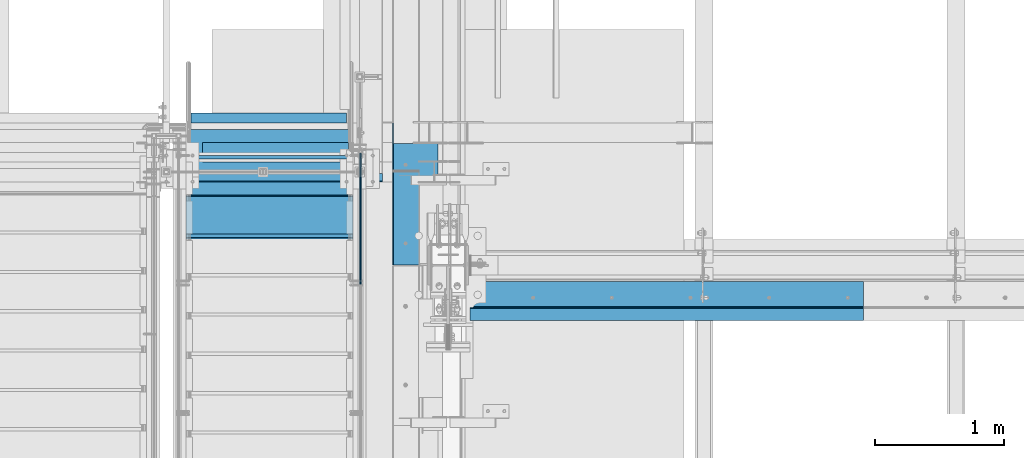
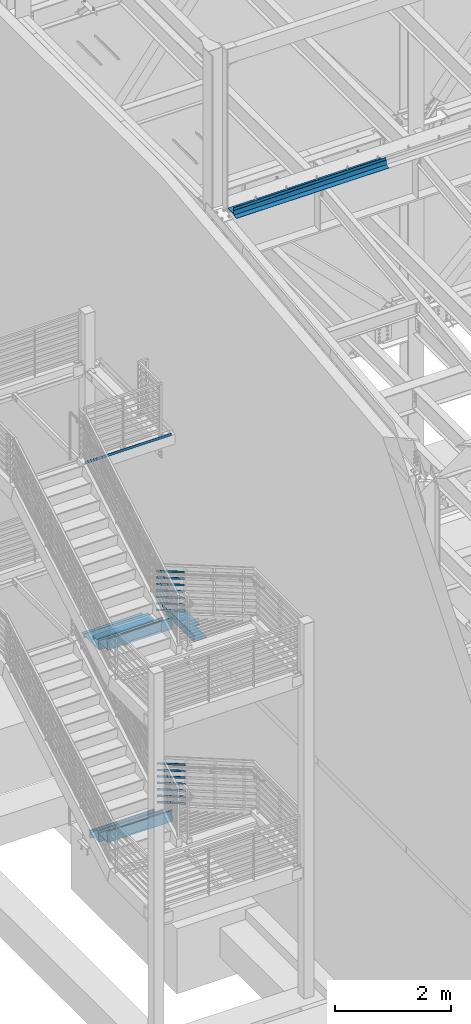
# One storey, part 763 of 1179: 14 members, 11 beams, 9 elements without a shape of their own.
"""IFC2X3 building model written with IfcOpenShell, lengths in millimetres."""

import ifcopenshell
import ifcopenshell.guid

model = None  # the IFC model being written
_history = None  # IfcOwnerHistory: only IFC2X3 demands one
_inside = {}  # id of a spatial element -> (the spatial element, [elements in it])
_under = {}  # id of a project, library or spatial element -> (it, [spatial elements below it])
_declared = {}  # id of a project -> (the project, [libraries it declares])
_typed = {}  # id of a type object -> (the type object, [elements of that type])
_made_of = {}  # id of a material, layer set ... -> (it, [elements and type objects made of it])


def new_model(schema):
    """Start an empty IFC model of exactly this schema.

    Asked for "IFC4X3", IfcOpenShell would pick the latest addendum, in which some entities
    have other attributes; the version numbers below select the first issue.
    IFC2X3 requires an IfcOwnerHistory on every rooted entity: one is made here for all.
    """
    global model, _history
    if schema == "IFC4X3":
        model = ifcopenshell.file(schema_version=(4, 3, 0, 0))
    else:
        model = ifcopenshell.file(schema=schema)
    _inside.clear()
    _under.clear()
    _declared.clear()
    _typed.clear()
    _made_of.clear()
    _history = None
    if model.schema == "IFC2X3":
        org = make("IfcOrganization", Name="unknown")
        user = make(
            "IfcPersonAndOrganization",
            ThePerson=make("IfcPerson", FamilyName="unknown"),
            TheOrganization=org,
        )
        app = make(
            "IfcApplication",
            ApplicationDeveloper=org,
            Version="unknown",
            ApplicationFullName="unknown",
            ApplicationIdentifier="unknown",
        )
        _history = make(
            "IfcOwnerHistory",
            OwningUser=user,
            OwningApplication=app,
            ChangeAction="ADDED",
            CreationDate=0,
        )
    return model


def make(cls, **values):
    """One entity of the class cls with the attributes given. An attribute that is None is left unset."""
    return model.create_entity(
        cls, **{name: value for name, value in values.items() if value is not None}
    )


def rooted(cls, **values):
    """An entity with a GlobalId (a new one), such as an element, a storey or a relation."""
    return make(cls, GlobalId=ifcopenshell.guid.new(), OwnerHistory=_history, **values)


def si_unit(unit_type, name, prefix=None):
    """IfcSIUnit, for example si_unit("LENGTHUNIT", "METRE", prefix="MILLI")."""
    return make("IfcSIUnit", UnitType=unit_type, Prefix=prefix, Name=name)


def assignment(units):
    """IfcUnitAssignment: the units of a project."""
    return None if units is None else make("IfcUnitAssignment", Units=units)


def point(xyz):
    """IfcCartesianPoint."""
    return None if xyz is None else make("IfcCartesianPoint", Coordinates=xyz)


def direction(xyz):
    """IfcDirection."""
    return None if xyz is None else make("IfcDirection", DirectionRatios=xyz)


def frame(location, z_axis=None, x_axis=None):
    """IfcAxis2Placement3D, a coordinate frame: its origin and axes. An axis left out is left unset."""
    return make(
        "IfcAxis2Placement3D",
        Location=point(location),
        Axis=direction(z_axis),
        RefDirection=direction(x_axis),
    )


def origin_with_axes():
    """The frame at (0, 0, 0) with the z axis (0, 0, 1) and the x axis (1, 0, 0) written out."""
    return frame((0.0, 0.0, 0.0), z_axis=(0.0, 0.0, 1.0), x_axis=(1.0, 0.0, 0.0))


def place(relative_to, where):
    """IfcLocalPlacement: puts the frame where relative to a parent placement (None: the world)."""
    return make(
        "IfcLocalPlacement", PlacementRelTo=relative_to, RelativePlacement=where
    )


def context(
    kind, dimensions, precision=None, world=None, true_north=None, identifier=None
):
    """IfcGeometricRepresentationContext, for example the 3D "Model" context."""
    return make(
        "IfcGeometricRepresentationContext",
        ContextIdentifier=identifier,
        ContextType=kind,
        CoordinateSpaceDimension=dimensions,
        Precision=precision,
        WorldCoordinateSystem=world,
        TrueNorth=true_north,
    )


def subcontext(parent, identifier, kind, view, scale=None):
    """IfcGeometricRepresentationSubContext, for example "Body" below "Model"."""
    return make(
        "IfcGeometricRepresentationSubContext",
        ContextIdentifier=identifier,
        ContextType=kind,
        ParentContext=parent,
        TargetScale=scale,
        TargetView=view,
    )


def project(units=None, contexts=None):
    """IfcProject with its units and contexts."""
    return rooted(
        "IfcProject",
        Name="project",
        RepresentationContexts=contexts,
        UnitsInContext=assignment(units),
    )


def spatial(cls, under=None, at=None, **own):
    """A site, building, storey or space (cls), placed at a placement, below another one or the project."""
    s = rooted(cls, ObjectPlacement=at, **own)
    if under is not None:
        _under.setdefault(under.id(), (under, []))[1].append(s)
    return s


def faces_of(points, faces, orient=None, outer=None):
    """IfcFace entities. A face is a list of loops; a loop is a list of indices into points, from 0.

    orient and outer hold one flag for each loop. By default every Orientation is true, the
    first loop of a face is its IfcFaceOuterBound and the others are IfcFaceBound.
    """
    made = []
    for i, loops in enumerate(faces):
        bounds = []
        for j, loop in enumerate(loops):
            is_outer = j == 0 if outer is None else outer[i][j]
            bounds.append(
                make(
                    "IfcFaceOuterBound" if is_outer else "IfcFaceBound",
                    Bound=make("IfcPolyLoop", Polygon=[points[k] for k in loop]),
                    Orientation=True if orient is None else orient[i][j],
                )
            )
        made.append(make("IfcFace", Bounds=bounds))
    return made


def faceted_brep(points, faces, orient=None, outer=None, voids=None):
    """IfcFacetedBrep: a solid bounded by flat faces; with voids (closed shells), ...WithVoids."""
    shared = [point(p) for p in points]
    hull = make("IfcClosedShell", CfsFaces=faces_of(shared, faces, orient, outer))
    if voids is None:
        return make("IfcFacetedBrep", Outer=hull)
    return make(
        "IfcFacetedBrepWithVoids",
        Outer=hull,
        Voids=[
            make(cls, CfsFaces=faces_of(shared, fs, o, b)) for cls, fs, o, b in voids
        ],
    )


def shape(context_of_items, identifier, shape_type, items):
    """IfcShapeRepresentation: the items that make up one representation, for example the "Body"."""
    return make(
        "IfcShapeRepresentation",
        ContextOfItems=context_of_items,
        RepresentationIdentifier=identifier,
        RepresentationType=shape_type,
        Items=items,
    )


def material(Name=None, Category=None):
    """IfcMaterial."""
    return make("IfcMaterial", Name=Name, Category=Category)


def made_of(thing, what):
    """Note that an element or type object is made of a material, layer set ...; save() writes the relation."""
    if what is not None:
        _made_of.setdefault(what.id(), (what, []))[1].append(thing)
    return thing


def type_object(cls, material=None, **own):
    """A type object (cls), such as IfcWallType, which elements share."""
    return made_of(rooted(cls, **own), material)


def element(
    cls,
    number,
    at=None,
    inside=None,
    cuts=None,
    type_object=None,
    material=None,
    context=None,
    identifier="Body",
    shape_type=None,
    held_by="IfcProductDefinitionShape",
    body=None,
    shapes=None,
    **own,
):
    """One element of the class cls, such as IfcWall. Its Tag is "e" and its number.

    at: its placement. inside: the storey or other place that contains it. cuts: it is an
    opening in that element (IfcRelVoidsElement). A single representation is given by context,
    identifier, shape_type and body (its items); several are given by shapes. held_by: the class
    of the entity that holds the representations. save() writes the other relations.
    """
    e = rooted(cls, Tag="e%d" % number, ObjectPlacement=at, **own)
    if body is not None:
        shapes = [shape(context, identifier, shape_type, body)]
    if shapes is not None:
        e.Representation = make(held_by, Representations=shapes)
    if inside is not None:
        _inside.setdefault(inside.id(), (inside, []))[1].append(e)
    if cuts is not None:
        rooted(
            "IfcRelVoidsElement", RelatingBuildingElement=cuts, RelatedOpeningElement=e
        )
    if type_object is not None:
        _typed.setdefault(type_object.id(), (type_object, []))[1].append(e)
    return made_of(e, material)


def aggregate(whole, parts):
    """IfcRelAggregates: a whole, such as a stair, and the parts it consists of."""
    return rooted("IfcRelAggregates", RelatingObject=whole, RelatedObjects=parts)


def save(model, path):
    """Write the relations noted so far, then the file.

    IfcRelAggregates (storeys below a building ...), IfcRelContainedInSpatialStructure (elements
    in a storey), IfcRelDefinesByType, IfcRelAssociatesMaterial and IfcRelDeclares: one each for
    every whole, place, type object, material and project.
    """
    for whole, parts in _under.values():
        aggregate(whole, parts)
    for where, things in _inside.values():
        rooted(
            "IfcRelContainedInSpatialStructure",
            RelatedElements=things,
            RelatingStructure=where,
        )
    for kind, things in _typed.values():
        rooted("IfcRelDefinesByType", RelatedObjects=things, RelatingType=kind)
    for what, things in _made_of.values():
        rooted("IfcRelAssociatesMaterial", RelatedObjects=things, RelatingMaterial=what)
    for by, libraries in _declared.values():
        rooted("IfcRelDeclares", RelatingContext=by, RelatedDefinitions=libraries)
    model.write(path)


model = new_model("IFC2X3")

# Units and contexts
model_context = context("Model", 3, precision=1e-05, world=origin_with_axes())
body_context = subcontext(model_context, "Body", "Model", "MODEL_VIEW")
ifc_project = project(units=[si_unit("LENGTHUNIT", "METRE", prefix="MILLI"), si_unit("AREAUNIT", "SQUARE_METRE"), si_unit("VOLUMEUNIT", "CUBIC_METRE"), si_unit("MASSUNIT", "GRAM", prefix="KILO"), si_unit("TIMEUNIT", "SECOND"), si_unit("PLANEANGLEUNIT", "RADIAN"), si_unit("SOLIDANGLEUNIT", "STERADIAN"), si_unit("THERMODYNAMICTEMPERATUREUNIT", "DEGREE_CELSIUS"), si_unit("LUMINOUSINTENSITYUNIT", "LUMEN")], contexts=[model_context])

# Site, building, storey
site_placement = place(None, origin_with_axes())
site = spatial("IfcSite", under=ifc_project, at=site_placement, CompositionType="ELEMENT")
building_placement = place(site_placement, origin_with_axes())
building = spatial("IfcBuilding", under=site, at=building_placement, Name="Undefined", CompositionType="ELEMENT")
storey_placement = place(building_placement, origin_with_axes())
storey = spatial("IfcBuildingStorey", under=building, at=storey_placement, Name="Undefined", CompositionType="ELEMENT", Elevation=0.0)

# Assembly, beam
assembly_1_placement = place(storey_placement, origin_with_axes())
assembly_1 = element("IfcElementAssembly", 1, at=assembly_1_placement, inside=storey, Name="BEAM", AssemblyPlace="NOTDEFINED", PredefinedType="RIGID_FRAME")
ifc_material = material(Name="STEEL/A36")
beam_type_1 = type_object("IfcBeamType", Name="L3X3X1/4", PredefinedType="NOTDEFINED")
beam_1_placement = place(assembly_1_placement, frame((-1562.09999973749, 35534.6000000027, 4095.75), z_axis=(0.0, 0.0, -1.0), x_axis=(1.0, 0.0, 0.0)))
beam_1 = element("IfcBeam", 2, at=beam_1_placement, type_object=beam_type_1, material=ifc_material, Name="ANGLE", ObjectType="L3X3X1/4", context=body_context, shape_type="Brep", body=[
    faceted_brep([(0.0, 38.0999999999985, -38.0999999999999), (0.0, 38.0999999999985, 38.0999999999999), (1206.49999973749, 38.0999999999985, 38.0999999999999), (1206.49999973749, 38.0999999999985, -38.1000000000004), (0.0, 31.75, 38.1000000000004), (1206.49999973749, 31.75, 38.0999999999999), (0.0, 31.75, -31.75), (1206.49999973749, 31.75, -31.75), (0.0, -38.0999999999985, -31.75), (1206.49999973749, -38.0999999999985, -31.75), (0.0, -38.0999999999985, -38.0999999999999), (1206.49999973749, -38.0999999999985, -38.1000000000004)], [[[0, 1, 2, 3]], [[1, 4, 5, 2]], [[4, 6, 7, 5]], [[6, 8, 9, 7]], [[8, 10, 11, 9]], [[10, 0, 3, 11]], [[5, 7, 9, 11, 3, 2]], [[10, 8, 6, 4, 1, 0]]]),
])

# Assembly, members
assembly_2_placement = place(storey_placement, origin_with_axes())
assembly_2 = element("IfcElementAssembly", 3, at=assembly_2_placement, inside=storey, Name="GUARDRAIL", AssemblyPlace="NOTDEFINED", PredefinedType="RIGID_FRAME")
member_type = type_object("IfcMemberType", PredefinedType="NOTDEFINED")
member_1_placement = place(assembly_2_placement, frame((-247.650000724804, 35271.0012572226, 4335.52619387723), z_axis=(0.0, 0.503871025834968, 0.863778900717086), x_axis=(0.0, -0.863778900717086, 0.503871025834967)))
member_1 = element("IfcMember", 4, at=member_1_placement, type_object=member_type, material=ifc_material, Name="PLATE", context=body_context, shape_type="Brep", body=[
    faceted_brep([(-0.170746091993351, 4.76249999999999, -19.0500000000247), (22.0542539263261, 4.76249999999999, 19.0500000000065), (1164.83261782332, 4.76250000000005, 19.0499999989988), (1142.607617805, 4.76250000000005, -19.0500000010361), (22.0542539263261, -4.76249999999999, 19.0500000000065), (1164.83261782332, -4.76250000000005, 19.0499999989988), (-0.170746091993351, -4.76249999999999, -19.0500000000247), (1142.607617805, -4.76250000000005, -19.0500000010361)], [[[0, 1, 2, 3]], [[1, 4, 5, 2]], [[4, 6, 7, 5]], [[6, 0, 3, 7]], [[5, 7, 3, 2]], [[6, 4, 1, 0]]]),
])
member_2_placement = place(assembly_2_placement, frame((-247.650000724804, 35271.0012572185, 4471.70970347572), z_axis=(0.0, 0.503871025834968, 0.863778900717086), x_axis=(0.0, -0.863778900717086, 0.503871025834967)))
member_2 = element("IfcMember", 5, at=member_2_placement, type_object=member_type, material=ifc_material, Name="PLATE", context=body_context, shape_type="Brep", body=[
    faceted_brep([(-0.170746091993351, 4.76249999999999, -19.0500000000247), (22.0542539263261, 4.76249999999999, 19.0500000000065), (1164.83261782332, 4.76250000000005, 19.0499999989988), (1142.607617805, 4.76250000000005, -19.0500000010361), (22.0542539263261, -4.76249999999999, 19.0500000000065), (1164.83261782332, -4.76250000000005, 19.0499999989988), (-0.170746091993351, -4.76249999999999, -19.0500000000247), (1142.607617805, -4.76250000000005, -19.0500000010361)], [[[0, 1, 2, 3]], [[1, 4, 5, 2]], [[4, 6, 7, 5]], [[6, 0, 3, 7]], [[5, 7, 3, 2]], [[6, 4, 1, 0]]]),
])
member_3_placement = place(assembly_2_placement, frame((-247.650000724804, 35271.0012572142, 4607.89321307448), z_axis=(0.0, 0.503871025834968, 0.863778900717086), x_axis=(0.0, -0.863778900717086, 0.503871025834967)))
member_3 = element("IfcMember", 6, at=member_3_placement, type_object=member_type, material=ifc_material, Name="PLATE", context=body_context, shape_type="Brep", body=[
    faceted_brep([(-0.170746091993351, 4.76249999999999, -19.0500000000247), (22.0542539263261, 4.76249999999999, 19.0500000000065), (1164.83261782332, 4.76250000000005, 19.0499999989988), (1142.607617805, 4.76250000000005, -19.0500000010361), (22.0542539263261, -4.76249999999999, 19.0500000000065), (1164.83261782332, -4.76250000000005, 19.0499999989988), (-0.170746091993351, -4.76249999999999, -19.0500000000247), (1142.607617805, -4.76250000000005, -19.0500000010361)], [[[0, 1, 2, 3]], [[1, 4, 5, 2]], [[4, 6, 7, 5]], [[6, 0, 3, 7]], [[5, 7, 3, 2]], [[6, 4, 1, 0]]]),
])
member_4_placement = place(assembly_2_placement, frame((-247.650000724804, 35271.00125721, 4744.07672267268), z_axis=(0.0, 0.503871025834968, 0.863778900717086), x_axis=(0.0, -0.863778900717086, 0.503871025834967)))
member_4 = element("IfcMember", 7, at=member_4_placement, type_object=member_type, material=ifc_material, Name="PLATE", context=body_context, shape_type="Brep", body=[
    faceted_brep([(-0.170746091993351, 4.76249999999999, -19.0500000000247), (22.0542539263261, 4.76249999999999, 19.0500000000065), (1164.83261782332, 4.76250000000005, 19.0499999989988), (1142.607617805, 4.76250000000005, -19.0500000010361), (22.0542539263261, -4.76249999999999, 19.0500000000065), (1164.83261782332, -4.76250000000005, 19.0499999989988), (-0.170746091993351, -4.76249999999999, -19.0500000000247), (1142.607617805, -4.76250000000005, -19.0500000010361)], [[[0, 1, 2, 3]], [[1, 4, 5, 2]], [[4, 6, 7, 5]], [[6, 0, 3, 7]], [[5, 7, 3, 2]], [[6, 4, 1, 0]]]),
])
member_5_placement = place(assembly_2_placement, frame((-247.650000724804, 35271.0012572057, 4880.26023227058), z_axis=(0.0, 0.503871025834968, 0.863778900717086), x_axis=(0.0, -0.863778900717086, 0.503871025834967)))
member_5 = element("IfcMember", 8, at=member_5_placement, type_object=member_type, material=ifc_material, Name="PLATE", context=body_context, shape_type="Brep", body=[
    faceted_brep([(-0.170746091993351, 4.76249999999999, -19.0500000000247), (22.0542539263261, 4.76249999999999, 19.0500000000065), (1164.83261782332, 4.76250000000005, 19.0499999989988), (1142.607617805, 4.76250000000005, -19.0500000010361), (22.0542539263261, -4.76249999999999, 19.0500000000065), (1164.83261782332, -4.76250000000005, 19.0499999989988), (-0.170746091993351, -4.76249999999999, -19.0500000000247), (1142.607617805, -4.76250000000005, -19.0500000010361)], [[[0, 1, 2, 3]], [[1, 4, 5, 2]], [[4, 6, 7, 5]], [[6, 0, 3, 7]], [[5, 7, 3, 2]], [[6, 4, 1, 0]]]),
])
member_6_placement = place(assembly_2_placement, frame((-247.650000724804, 35271.0012572249, 5152.62725197387), z_axis=(0.0, 0.503871025834968, 0.863778900717086), x_axis=(0.0, -0.863778900717086, 0.503871025834967)))
member_6 = element("IfcMember", 9, at=member_6_placement, type_object=member_type, material=ifc_material, Name="PLATE", context=body_context, shape_type="Brep", body=[
    faceted_brep([(-0.170746091993351, 4.76249999999999, -19.0500000000247), (22.0542539263261, 4.76249999999999, 19.0500000000065), (1164.83261782332, 4.76250000000005, 19.0499999989988), (1142.607617805, 4.76250000000005, -19.0500000010361), (22.0542539263261, -4.76249999999999, 19.0500000000065), (1164.83261782332, -4.76250000000005, 19.0499999989988), (-0.170746091993351, -4.76249999999999, -19.0500000000247), (1142.607617805, -4.76250000000005, -19.0500000010361)], [[[0, 1, 2, 3]], [[1, 4, 5, 2]], [[4, 6, 7, 5]], [[6, 0, 3, 7]], [[5, 7, 3, 2]], [[6, 4, 1, 0]]]),
])
member_7_placement = place(assembly_2_placement, frame((-247.650000724804, 35271.0012572016, 5016.44374186906), z_axis=(0.0, 0.503871025834968, 0.863778900717086), x_axis=(0.0, -0.863778900717086, 0.503871025834967)))
member_7 = element("IfcMember", 10, at=member_7_placement, type_object=member_type, material=ifc_material, Name="PLATE", context=body_context, shape_type="Brep", body=[
    faceted_brep([(-0.170746091993351, 4.76249999999999, -19.0500000000247), (22.0542539263261, 4.76249999999999, 19.0500000000065), (1164.83261782332, 4.76250000000005, 19.0499999989988), (1142.607617805, 4.76250000000005, -19.0500000010361), (22.0542539263261, -4.76249999999999, 19.0500000000065), (1164.83261782332, -4.76250000000005, 19.0499999989988), (-0.170746091993351, -4.76249999999999, -19.0500000000247), (1142.607617805, -4.76250000000005, -19.0500000010361)], [[[0, 1, 2, 3]], [[1, 4, 5, 2]], [[4, 6, 7, 5]], [[6, 0, 3, 7]], [[5, 7, 3, 2]], [[6, 4, 1, 0]]]),
])
aggregate(assembly_2, [member_1, member_2, member_3, member_4, member_5, member_6, member_7])

assembly_3_placement = place(storey_placement, origin_with_axes())
assembly_3 = element("IfcElementAssembly", 11, at=assembly_3_placement, inside=storey, Name="GUARDRAIL", AssemblyPlace="NOTDEFINED", PredefinedType="RIGID_FRAME")
member_8_placement = place(assembly_3_placement, frame((-247.650000724804, 35232.9545867769, 299.274981469476), z_axis=(0.0, 0.501075923252298, 0.865403327435744), x_axis=(0.0, -0.865403327435743, 0.501075923252299)))
member_8 = element("IfcMember", 12, at=member_8_placement, type_object=member_type, material=ifc_material, Name="PLATE", context=body_context, shape_type="Brep", body=[
    faceted_brep([(-0.0473691999795847, 4.76250000000005, -19.0500000000138), (22.0128564435363, 4.76250000000005, 19.0500000000102), (1153.84060725657, 4.76250000000005, 19.0499999998246), (1131.78038161306, 4.76250000000005, -19.0500000001994), (22.0128564435363, -4.76250000000005, 19.0500000000102), (1153.84060725657, -4.76250000000005, 19.0499999998246), (-0.0473691999795847, -4.76250000000005, -19.0500000000138), (1131.78038161306, -4.76250000000005, -19.0500000001994)], [[[0, 1, 2, 3]], [[1, 4, 5, 2]], [[4, 6, 7, 5]], [[6, 0, 3, 7]], [[5, 7, 3, 2]], [[6, 4, 1, 0]]]),
])
member_9_placement = place(assembly_3_placement, frame((-247.650000724804, 35232.9545713406, 435.375696171575), z_axis=(0.0, 0.501075923252298, 0.865403327435744), x_axis=(0.0, -0.865403327435743, 0.501075923252299)))
member_9 = element("IfcMember", 13, at=member_9_placement, type_object=member_type, material=ifc_material, Name="PLATE", context=body_context, shape_type="Brep", body=[
    faceted_brep([(-0.0473691999795847, 4.76250000000005, -19.0500000000138), (22.0128564435363, 4.76250000000005, 19.0500000000102), (1153.84060725657, 4.76250000000005, 19.0499999998246), (1131.78038161306, 4.76250000000005, -19.0500000001994), (22.0128564435363, -4.76250000000005, 19.0500000000102), (1153.84060725657, -4.76250000000005, 19.0499999998246), (-0.0473691999795847, -4.76250000000005, -19.0500000000138), (1131.78038161306, -4.76250000000005, -19.0500000001994)], [[[0, 1, 2, 3]], [[1, 4, 5, 2]], [[4, 6, 7, 5]], [[6, 0, 3, 7]], [[5, 7, 3, 2]], [[6, 4, 1, 0]]]),
])
member_10_placement = place(assembly_3_placement, frame((-247.650000724804, 35232.9545553325, 571.476410876199), z_axis=(0.0, 0.501075923252298, 0.865403327435744), x_axis=(0.0, -0.865403327435743, 0.501075923252299)))
member_10 = element("IfcMember", 14, at=member_10_placement, type_object=member_type, material=ifc_material, Name="PLATE", context=body_context, shape_type="Brep", body=[
    faceted_brep([(-0.0473691999795847, 4.76250000000005, -19.0500000000138), (22.0128564435363, 4.76250000000005, 19.0500000000102), (1153.84060725657, 4.76250000000005, 19.0499999998246), (1131.78038161306, 4.76250000000005, -19.0500000001994), (22.0128564435363, -4.76250000000005, 19.0500000000102), (1153.84060725657, -4.76250000000005, 19.0499999998246), (-0.0473691999795847, -4.76250000000005, -19.0500000000138), (1131.78038161306, -4.76250000000005, -19.0500000001994)], [[[0, 1, 2, 3]], [[1, 4, 5, 2]], [[4, 6, 7, 5]], [[6, 0, 3, 7]], [[5, 7, 3, 2]], [[6, 4, 1, 0]]]),
])
member_11_placement = place(assembly_3_placement, frame((-247.650000724804, 35232.9545387317, 707.577125627306), z_axis=(0.0, 0.501075923252298, 0.865403327435744), x_axis=(0.0, -0.865403327435743, 0.501075923252299)))
member_11 = element("IfcMember", 15, at=member_11_placement, type_object=member_type, material=ifc_material, Name="PLATE", context=body_context, shape_type="Brep", body=[
    faceted_brep([(-0.0473691999795847, 4.76250000000005, -19.0500000000138), (22.0128564435363, 4.76250000000005, 19.0500000000102), (1153.84060725657, 4.76250000000005, 19.0499999998246), (1131.78038161306, 4.76250000000005, -19.0500000001994), (22.0128564435363, -4.76250000000005, 19.0500000000102), (1153.84060725657, -4.76250000000005, 19.0499999998246), (-0.0473691999795847, -4.76250000000005, -19.0500000000138), (1131.78038161306, -4.76250000000005, -19.0500000001994)], [[[0, 1, 2, 3]], [[1, 4, 5, 2]], [[4, 6, 7, 5]], [[6, 0, 3, 7]], [[5, 7, 3, 2]], [[6, 4, 1, 0]]]),
])
member_12_placement = place(assembly_3_placement, frame((-247.650000724804, 35232.9545215159, 843.677840380916), z_axis=(0.0, 0.501075923252298, 0.865403327435744), x_axis=(0.0, -0.865403327435743, 0.501075923252299)))
member_12 = element("IfcMember", 16, at=member_12_placement, type_object=member_type, material=ifc_material, Name="PLATE", context=body_context, shape_type="Brep", body=[
    faceted_brep([(-0.0473691999795847, 4.76250000000005, -19.0500000000138), (22.0128564435363, 4.76250000000005, 19.0500000000102), (1153.84060725657, 4.76250000000005, 19.0499999998246), (1131.78038161306, 4.76250000000005, -19.0500000001994), (22.0128564435363, -4.76250000000005, 19.0500000000102), (1153.84060725657, -4.76250000000005, 19.0499999998246), (-0.0473691999795847, -4.76250000000005, -19.0500000000138), (1131.78038161306, -4.76250000000005, -19.0500000001994)], [[[0, 1, 2, 3]], [[1, 4, 5, 2]], [[4, 6, 7, 5]], [[6, 0, 3, 7]], [[5, 7, 3, 2]], [[6, 4, 1, 0]]]),
])
member_13_placement = place(assembly_3_placement, frame((-247.650000724804, 35232.9545036904, 1115.87926984463), z_axis=(0.0, 0.501075923252298, 0.865403327435744), x_axis=(0.0, -0.865403327435743, 0.501075923252299)))
member_13 = element("IfcMember", 17, at=member_13_placement, type_object=member_type, material=ifc_material, Name="PLATE", context=body_context, shape_type="Brep", body=[
    faceted_brep([(-0.0473691999795847, 4.76250000000005, -19.0500000000138), (22.0128564435363, 4.76250000000005, 19.0500000000102), (1153.84060725657, 4.76250000000005, 19.0499999998246), (1131.78038161306, 4.76250000000005, -19.0500000001994), (22.0128564435363, -4.76250000000005, 19.0500000000102), (1153.84060725657, -4.76250000000005, 19.0499999998246), (-0.0473691999795847, -4.76250000000005, -19.0500000000138), (1131.78038161306, -4.76250000000005, -19.0500000001994)], [[[0, 1, 2, 3]], [[1, 4, 5, 2]], [[4, 6, 7, 5]], [[6, 0, 3, 7]], [[5, 7, 3, 2]], [[6, 4, 1, 0]]]),
])
member_14_placement = place(assembly_3_placement, frame((-247.650000724804, 35232.9545036625, 979.778555134521), z_axis=(0.0, 0.501075923252298, 0.865403327435744), x_axis=(0.0, -0.865403327435743, 0.501075923252299)))
member_14 = element("IfcMember", 18, at=member_14_placement, type_object=member_type, material=ifc_material, Name="PLATE", context=body_context, shape_type="Brep", body=[
    faceted_brep([(-0.0473691999795847, 4.76250000000005, -19.0500000000138), (22.0128564435363, 4.76250000000005, 19.0500000000102), (1153.84060725657, 4.76250000000005, 19.0499999998246), (1131.78038161306, 4.76250000000005, -19.0500000001994), (22.0128564435363, -4.76250000000005, 19.0500000000102), (1153.84060725657, -4.76250000000005, 19.0499999998246), (-0.0473691999795847, -4.76250000000005, -19.0500000000138), (1131.78038161306, -4.76250000000005, -19.0500000001994)], [[[0, 1, 2, 3]], [[1, 4, 5, 2]], [[4, 6, 7, 5]], [[6, 0, 3, 7]], [[5, 7, 3, 2]], [[6, 4, 1, 0]]]),
])
aggregate(assembly_3, [member_8, member_9, member_10, member_11, member_12, member_13, member_14])

# Beam
beam_type_2 = type_object("IfcBeamType", Name="L6X3-1/2X3/8", PredefinedType="NOTDEFINED")
beam_2_placement = place(assembly_1_placement, frame((-1473.19999987718, 35267.9000000027, 4137.02499999882), z_axis=(0.0, -1.0, 0.0), x_axis=(1.0, 0.0, 0.0)))
beam_2 = element("IfcBeam", 19, at=beam_2_placement, type_object=beam_type_2, material=ifc_material, Name="ANGLE", ObjectType="L6X3-1/2X3/8", context=body_context, shape_type="Brep", body=[
    faceted_brep([(0.0, 44.4499999999998, -76.1999999999971), (0.0, 44.4499999999998, 76.1999999999971), (1133.47499978257, 44.4499999999998, 76.1999999999971), (1133.47499978257, 44.4499999999998, -76.1999999999971), (0.0, 34.9250000000002, 76.1999999999971), (1133.47499978257, 34.9250000000002, 76.1999999999971), (0.0, 34.9250000000002, -66.6750000000029), (1133.47499978257, 34.9250000000002, -66.6750000000029), (0.0, -44.4499999999998, -66.6750000000029), (1133.47499978257, -44.4499999999998, -66.6750000000029), (0.0, -44.4499999999998, -76.1999999999971), (1133.47499978257, -44.4499999999998, -76.1999999999971)], [[[0, 1, 2, 3]], [[1, 4, 5, 2]], [[4, 6, 7, 5]], [[6, 8, 9, 7]], [[8, 10, 11, 9]], [[10, 0, 3, 11]], [[5, 7, 9, 11, 3, 2]], [[10, 8, 6, 4, 1, 0]]]),
])

aggregate(assembly_1, [beam_1, beam_2])

# Assembly, beams
assembly_4_placement = place(storey_placement, origin_with_axes())
assembly_4 = element("IfcElementAssembly", 20, at=assembly_4_placement, inside=storey, Name="STRINGER", AssemblyPlace="NOTDEFINED", PredefinedType="RIGID_FRAME")
beam_type_3 = type_object("IfcBeamType", PredefinedType="NOTDEFINED")
beam_3_placement = place(assembly_4_placement, frame((-952.499999979436, 34607.5013836102, 527.853371605209), z_axis=(-1.0, 0.0, 0.0), x_axis=(0.0, 1.0, 0.0)))
beam_3 = element("IfcBeam", 21, at=beam_3_placement, type_object=beam_type_3, material=ifc_material, Name="TREAD", context=body_context, shape_type="Brep", body=[
    faceted_brep([(-5.47515810467303e-10, -1.58750000000146, -647.7), (-5.47515810467303e-10, -1.58750000000146, 647.7), (5.49334799870849e-10, 1.58749999999418, 647.7), (5.49334799870849e-10, 1.58749999999418, -647.7), (21.7353257776667, 1.58750000000009, 647.7), (21.7353257776667, 1.58750000000009, -647.7), (25.4000000001688, -1.58750000000009, -647.7), (25.4000000001688, -1.58750000000009, 647.7), (-10.9760191413625, 228.869394137143, 647.7), (-10.9760191413625, 228.869394137143, -647.7), (-7.31134491886041, 225.694394137142, -647.7), (-7.31134491886041, 225.694394137142, 647.7), (319.224134592409, 228.869394137143, 647.7), (319.224134592409, 228.869394137143, -647.7), (316.473378484785, 225.694394137142, -647.7), (316.473378484785, 225.694394137142, 647.7), (325.043579912828, 188.435270791671, 647.7), (325.043579912828, 188.435270791671, -647.7), (321.900961419207, 187.982972213801, 647.7), (321.900961419207, 187.982972213801, -647.7)], [[[0, 1, 2, 3]], [[3, 2, 4, 5]], [[1, 0, 6, 7]], [[5, 4, 8, 9]], [[7, 6, 10, 11]], [[9, 8, 12, 13]], [[11, 10, 14, 15]], [[13, 12, 16, 17]], [[12, 8, 4, 2, 1, 7, 11, 15, 18, 16]], [[15, 14, 19, 18]], [[14, 10, 6, 0, 3, 5, 9, 13, 17, 19]], [[18, 19, 17, 16]]]),
])
beam_4_placement = place(assembly_4_placement, frame((-952.499999979396, 34912.3015373443, 351.371477468066), z_axis=(-1.0, 0.0, 0.0), x_axis=(0.0, 1.0, 0.0)))
beam_4 = element("IfcBeam", 22, at=beam_4_placement, type_object=beam_type_3, material=ifc_material, Name="TREAD", context=body_context, shape_type="Brep", body=[
    faceted_brep([(-5.47515810467303e-10, -1.58750000000146, -647.7), (-5.47515810467303e-10, -1.58750000000146, 647.7), (5.49334799870849e-10, 1.58749999999418, 647.7), (5.49334799870849e-10, 1.58749999999418, -647.7), (21.7353257776667, 1.58750000000009, 647.7), (21.7353257776667, 1.58750000000009, -647.7), (25.4000000001688, -1.58750000000009, -647.7), (25.4000000001688, -1.58750000000009, 647.7), (-10.9760191413625, 228.869394137143, 647.7), (-10.9760191413625, 228.869394137143, -647.7), (-7.31134491886041, 225.694394137142, -647.7), (-7.31134491886041, 225.694394137142, 647.7), (319.224134592409, 228.869394137143, 647.7), (319.224134592409, 228.869394137143, -647.7), (316.473378484785, 225.694394137142, -647.7), (316.473378484785, 225.694394137142, 647.7), (325.043579912828, 188.435270791671, 647.7), (325.043579912828, 188.435270791671, -647.7), (321.900961419207, 187.982972213801, 647.7), (321.900961419207, 187.982972213801, -647.7)], [[[0, 1, 2, 3]], [[3, 2, 4, 5]], [[1, 0, 6, 7]], [[5, 4, 8, 9]], [[7, 6, 10, 11]], [[9, 8, 12, 13]], [[11, 10, 14, 15]], [[13, 12, 16, 17]], [[12, 8, 4, 2, 1, 7, 11, 15, 18, 16]], [[15, 14, 19, 18]], [[14, 10, 6, 0, 3, 5, 9, 13, 17, 19]], [[18, 19, 17, 16]]]),
])

# Assembly, beam
assembly_5_placement = place(storey_placement, origin_with_axes())
assembly_5 = element("IfcElementAssembly", 23, at=assembly_5_placement, inside=storey, Name="BEAM", AssemblyPlace="NOTDEFINED", PredefinedType="RIGID_FRAME")
beam_type_4 = type_object("IfcBeamType", PredefinedType="NOTDEFINED")
beam_5_placement = place(assembly_5_placement, frame((-936.625002098729, 35102.800036508, 8096.25000344166), z_axis=(-1.0, 0.0, 0.0), x_axis=(0.0, -1.0, 0.0)))
beam_5 = element("IfcBeam", 24, at=beam_5_placement, type_object=beam_type_4, material=ifc_material, Name="BENT_PLATE", context=body_context, shape_type="Brep", body=[
    faceted_brep([(19.0500096681717, -3.17500000216842, -714.374998184761), (19.0500090585629, 3.17499999783104, -714.374998184761), (1.16415321826935e-09, 3.17500000000018, -714.374997460816), (4.43833414465189e-10, -3.17500000000018, -714.374997460816), (19.0500120810248, -3.17500000216933, -650.874998184761), (19.0500114714159, 3.17499999783104, -650.874998184761), (3.71073838323355e-10, -3.17500000000018, -650.874997460816), (1.09139364212751e-09, 3.17500000000018, -650.874997460816), (63.500001910521, -3.17500000722976, 860.424999999928), (63.5000019100116, -3.17500000722976, -860.425000000073), (63.4999967294498, 50.7999987117846, -860.425000000146), (63.4999967275944, 50.7999987142302, 860.424999999855), (19.050038139867, -3.17500000216842, 34.9249994962848), (19.0500375302581, 3.17499999783104, 34.9249994962847), (3.12866177409887e-10, 3.17500000000018, 34.9250002202299), (-4.00177668780088e-10, -3.17500000000018, 34.9250002202298), (19.05004055272, -3.17500000216933, 98.424999496285), (19.0500399431112, 3.17499999783104, 98.424999496285), (-4.72937244921923e-10, -3.17500000000018, 98.42500022023), (2.40106601268053e-10, 3.17500000000018, 98.42500022023), (-1.25146470963955e-09, -3.17500000000018, 784.224997901276), (-5.3114490583539e-10, 3.17500000000018, 784.224997901277), (19.0500666115549, -3.17500000216842, 784.22499717733), (19.0500660019534, 3.17499999783104, 784.22499717733), (19.0500687831081, -3.17500000216933, 860.42499999994), (19.0500681734993, 3.17499999783104, 860.424999999979), (57.1499967275959, 50.7999981046196, 860.424999999863), (57.150001300899, 3.17499999349366, 860.424999999936), (57.150001300397, 3.17499999349366, -860.425000000066), (57.149996729444, 50.799998102174, -860.425000000138), (6.03904481977224e-10, -3.17500000000018, -860.425), (1.32422428578138e-09, 3.17500000000018, -860.425)], [[[0, 1, 2, 3]], [[4, 5, 1, 0]], [[6, 7, 5, 4]], [[8, 9, 10, 11]], [[12, 13, 14, 15]], [[16, 17, 13, 12]], [[18, 19, 17, 16]], [[20, 21, 19, 18]], [[22, 23, 21, 20]], [[24, 25, 23, 22]], [[8, 11, 26, 27, 25, 24]], [[28, 27, 26, 29]], [[11, 10, 29, 26]], [[9, 30, 31, 28, 29, 10]], [[31, 30, 3, 2]], [[14, 13, 17, 19, 21, 23, 25, 27, 28, 31, 2, 1, 5, 7]], [[15, 14, 7, 6]], [[3, 30, 9, 8, 24, 22, 20, 18, 16, 12, 15, 6, 4, 0]]]),
])
aggregate(assembly_5, [beam_5])

assembly_6_placement = place(storey_placement, origin_with_axes())
assembly_6 = element("IfcElementAssembly", 25, at=assembly_6_placement, inside=storey, Name="BENT_PLATE", AssemblyPlace="NOTDEFINED", PredefinedType="RIGID_FRAME")
beam_type_5 = type_object("IfcBeamType", PredefinedType="NOTDEFINED")
beam_6_placement = place(assembly_6_placement, frame((2125.66250079684, 34061.4000000402, 13197.7319337816), z_axis=(1.0, 0.0, 0.0), x_axis=(0.0, 0.0, -1.0)))
beam_6 = element("IfcBeam", 26, at=beam_6_placement, type_object=beam_type_5, material=ifc_material, Name="BENT_PLATE", context=body_context, shape_type="Brep", body=[
    faceted_brep([(0.0, -3.17499999999927, -1524.0), (6.00266503170133e-10, -3.17499999922438, 1524.00000000052), (6.00266503170133e-10, 3.17500000077416, 1524.00000000052), (0.0, 3.17499999999927, -1524.0), (101.599999999993, 3.17500000000291, 1524.0), (101.599999999993, 3.17500000000291, -1524.0), (95.9271295501057, -3.17500000000291, -1524.0), (95.9271295501057, -3.17500000000291, 1524.0), (113.008063243053, -97.7824964679457, 1524.0), (113.008063243053, -97.7824964679457, -1524.0), (106.698219713815, -98.4955004206422, 1524.0), (106.698219713815, -98.4955004206422, -1524.0)], [[[0, 1, 2, 3]], [[3, 2, 4, 5]], [[1, 0, 6, 7]], [[5, 4, 8, 9]], [[4, 2, 1, 7, 10, 8]], [[7, 6, 11, 10]], [[6, 0, 3, 5, 9, 11]], [[10, 11, 9, 8]]]),
])
aggregate(assembly_6, [beam_6])

assembly_7_placement = place(storey_placement, origin_with_axes())
assembly_7 = element("IfcElementAssembly", 27, at=assembly_7_placement, inside=storey, Name="BEAM", AssemblyPlace="NOTDEFINED", PredefinedType="RIGID_FRAME")
beam_type_6 = type_object("IfcBeamType", PredefinedType="NOTDEFINED")
beam_7_placement = place(assembly_7_placement, frame((2125.66250081644, 34267.775, 13122.275), z_axis=(1.0, 0.0, 0.0), x_axis=(0.0, -1.0, 0.0)))
beam_7 = element("IfcBeam", 28, at=beam_7_placement, type_object=beam_type_6, material=ifc_material, Name="BENT_PLATE", context=body_context, shape_type="Brep", body=[
    faceted_brep([(0.0, -3.17499999999927, -1524.0), (6.00266503170133e-10, -3.17499999922438, 1524.00000000052), (6.00266503170133e-10, 3.17500000077416, 1524.00000000052), (0.0, 3.17499999999927, -1524.0), (203.199999999997, 3.17499999999927, 1524.0), (203.199999999997, 3.17499999999927, -1524.0), (196.849999999991, -3.17499999999927, -1524.0), (196.849999999991, -3.17499999999927, 1524.0), (203.199999999997, -130.175000000001, 1524.0), (203.199999999997, -130.175000000001, -1524.0), (196.849999999991, -130.175000000001, 1524.0), (196.849999999991, -130.175000000001, -1524.0)], [[[0, 1, 2, 3]], [[3, 2, 4, 5]], [[1, 0, 6, 7]], [[5, 4, 8, 9]], [[4, 2, 1, 7, 10, 8]], [[7, 6, 11, 10]], [[6, 0, 3, 5, 9, 11]], [[10, 11, 9, 8]]]),
])
aggregate(assembly_7, [beam_7])

assembly_8_placement = place(storey_placement, origin_with_axes())
assembly_8 = element("IfcElementAssembly", 29, at=assembly_8_placement, inside=storey, Name="STRINGER", AssemblyPlace="NOTDEFINED", PredefinedType="RIGID_FRAME")
beam_type_7 = type_object("IfcBeamType", PredefinedType="NOTDEFINED")
beam_8_placement = place(assembly_8_placement, frame((-952.500000005652, 34607.4999994493, 4589.4624990112), z_axis=(-1.0, 0.0, 0.0), x_axis=(0.0, 1.0, 0.0)))
beam_8 = element("IfcBeam", 30, at=beam_8_placement, type_object=beam_type_7, material=ifc_material, Name="TREAD", context=body_context, shape_type="Brep", body=[
    faceted_brep([(-5.47515810467303e-10, -1.58750000000146, -647.7), (-5.47515810467303e-10, -1.58750000000146, 647.7), (5.49334799870849e-10, 1.58749999999418, 647.7), (5.49334799870849e-10, 1.58749999999418, -647.7), (21.7391942417962, 1.58749999999964, 647.7), (21.7391942417962, 1.58749999999964, -647.7), (25.4000000001688, -1.58750000000009, -647.7), (25.4000000001688, -1.58750000000009, 647.7), (-10.9179486153444, 230.1875, 647.7), (-10.9179486153444, 230.1875, -647.7), (-7.25714285782306, 227.012500000001, -647.7), (-7.25714285782306, 227.012500000001, 647.7), (319.2820511338, 230.1875, 647.7), (319.2820511338, 230.1875, -647.7), (316.528388233419, 227.012500000001, -647.7), (316.528388233419, 227.012500000001, 647.7), (325.059631548502, 189.744437097058, 647.7), (325.059631548502, 189.744437097058, -647.7), (321.916541906132, 189.295424291005, 647.7), (321.916541906132, 189.295424291005, -647.7)], [[[0, 1, 2, 3]], [[3, 2, 4, 5]], [[1, 0, 6, 7]], [[5, 4, 8, 9]], [[7, 6, 10, 11]], [[9, 8, 12, 13]], [[11, 10, 14, 15]], [[13, 12, 16, 17]], [[12, 8, 4, 2, 1, 7, 11, 15, 18, 16]], [[15, 14, 19, 18]], [[14, 10, 6, 0, 3, 5, 9, 13, 17, 19]], [[18, 19, 17, 16]]]),
])

assembly_9_placement = place(storey_placement, origin_with_axes())
assembly_9 = element("IfcElementAssembly", 31, at=assembly_9_placement, inside=storey, Name="BEAM", AssemblyPlace="NOTDEFINED", PredefinedType="RIGID_FRAME")
beam_type_8 = type_object("IfcBeamType", PredefinedType="NOTDEFINED")
beam_9_placement = place(assembly_9_placement, frame((352.424987792969, 34945.6375, 4105.275), z_axis=(0.0, -1.0, 0.0), x_axis=(-1.0, 0.0, 0.0)))
beam_9 = element("IfcBeam", 32, at=beam_9_placement, type_object=beam_type_8, material=ifc_material, Name="BENT_PLATE", context=body_context, shape_type="Brep", body=[
    faceted_brep([(352.424987792969, -85.7249985799453, -392.112499488656), (346.074987771434, -85.7249985799453, -392.112499488656), (346.074987558042, -3.17500000000109, -392.112499931689), (346.074987558042, 3.17499999999927, -392.112499931689), (352.424987792969, 3.17499999999927, -392.112499488656), (352.424987792969, -85.7249985799463, -550.862500000003), (346.074987792969, -85.7249985799463, -550.862500000003), (58.737487558043, -3.17500000000018, -392.112499356757), (0.0, -3.17500000000018, -392.112499488656), (0.0, 3.17500000000018, -392.112499488656), (58.737487558043, 3.17500000000018, -392.112499356757), (346.074987792969, -130.175006103515, 550.862500000003), (346.074987792969, -130.175006103515, -392.112499931689), (346.074987792969, -130.175006103515, -550.862500000003), (352.424987792969, -130.175006103515, -550.862500000003), (352.424987792969, -130.175006103515, 550.862500000003), (88.8999862670898, -3.17500000000018, 147.637500000012), (88.8999862670898, 3.17500000000018, 147.637500000012), (0.0, 3.17500000000018, 147.637500000012), (0.0, -3.17500000000018, 147.637500000012), (88.8999862670898, -3.17500000000018, 550.862500000003), (88.8999862670898, 3.17500000000018, 550.862500000003), (346.074987792969, -3.17500000000109, 550.862500000003), (352.424987792969, 3.17499999999927, 550.862500000003)], [[[0, 1, 2, 3, 4]], [[5, 6, 1, 0]], [[7, 8, 9, 10]], [[7, 10, 3, 2]], [[11, 12, 13, 14, 15]], [[16, 17, 18, 19]], [[20, 21, 17, 16]], [[22, 11, 15, 23, 21, 20]], [[13, 12, 11, 22, 2, 1, 6]], [[14, 13, 6, 5]], [[23, 15, 14, 5, 0, 4]], [[10, 9, 18, 17, 21, 23, 4, 3]], [[19, 18, 9, 8]], [[2, 22, 20, 16, 19, 8, 7]]]),
])
aggregate(assembly_9, [beam_9])

# Beam
beam_type_9 = type_object("IfcBeamType", PredefinedType="NOTDEFINED")
beam_10_placement = place(assembly_8_placement, frame((-952.500000010512, 34912.2999993759, 4411.66249890255), z_axis=(-1.0, 0.0, 0.0), x_axis=(0.0, 1.0, 0.0)))
beam_10 = element("IfcBeam", 33, at=beam_10_placement, type_object=beam_type_9, material=ifc_material, Name="TREAD", context=body_context, shape_type="Brep", body=[
    faceted_brep([(-5.47515810467303e-10, -1.58750000000146, -647.7), (-5.47515810467303e-10, -1.58750000000146, 647.7), (5.49334799870849e-10, 1.58749999999418, 647.7), (5.49334799870849e-10, 1.58749999999418, -647.7), (21.7319976818617, 1.58749999998054, 647.7), (21.7319976818617, 1.58749999998054, -647.7), (25.4000000001688, -1.58750000000009, -647.7), (25.4000000001688, -1.58750000000009, 647.7), (-11.3787166040602, 230.187500000011, 647.7), (-11.3787166040602, 230.187500000011, -647.7), (-7.71071428356299, 227.012500000008, -647.7), (-7.71071428356299, 227.012500000008, 647.7), (533.39999999979, 230.187499999515, 647.7), (533.39999999979, 230.187499999515, -647.7), (533.39999999979, 227.012499999516, 647.7), (533.39999999979, 227.012499999516, -647.7)], [[[0, 1, 2, 3]], [[3, 2, 4, 5]], [[1, 0, 6, 7]], [[5, 4, 8, 9]], [[7, 6, 10, 11]], [[9, 8, 12, 13]], [[8, 4, 2, 1, 7, 11, 14, 12]], [[11, 10, 15, 14]], [[10, 6, 0, 3, 5, 9, 13, 15]], [[14, 15, 13, 12]]]),
])

aggregate(assembly_8, [beam_8, beam_10])

beam_type_10 = type_object("IfcBeamType", PredefinedType="NOTDEFINED")
beam_11_placement = place(assembly_4_placement, frame((-952.499999979218, 35217.1016910801, 174.889583330756), z_axis=(-1.0, 0.0, 0.0), x_axis=(0.0, 1.0, 0.0)))
beam_11 = element("IfcBeam", 34, at=beam_11_placement, type_object=beam_type_10, material=ifc_material, Name="TREAD", context=body_context, shape_type="Brep", body=[
    faceted_brep([(-5.47515810467303e-10, -1.58750000000146, -647.7), (-5.47515810467303e-10, -1.58750000000146, 647.7), (5.49334799870849e-10, 1.58749999999418, 647.7), (5.49334799870849e-10, 1.58749999999418, -647.7), (21.7353257776667, 1.58750000000009, 647.7), (21.7353257776667, 1.58750000000009, -647.7), (25.4000000001688, -1.58750000000009, -647.7), (25.4000000001688, -1.58750000000009, 647.7), (-1.2760099537918, 161.472701423872, 647.7), (-1.2760099537918, 161.472701423872, -647.7), (1.86660853983631, 161.925000001742, 647.7), (1.86660853983631, 161.925000001742, -647.7)], [[[0, 1, 2, 3]], [[3, 2, 4, 5]], [[1, 0, 6, 7]], [[5, 4, 8, 9]], [[4, 2, 1, 7, 10, 8]], [[7, 6, 11, 10]], [[6, 0, 3, 5, 9, 11]], [[10, 11, 9, 8]]]),
])

aggregate(assembly_4, [beam_3, beam_4, beam_11])

save(model, "model.ifc")
